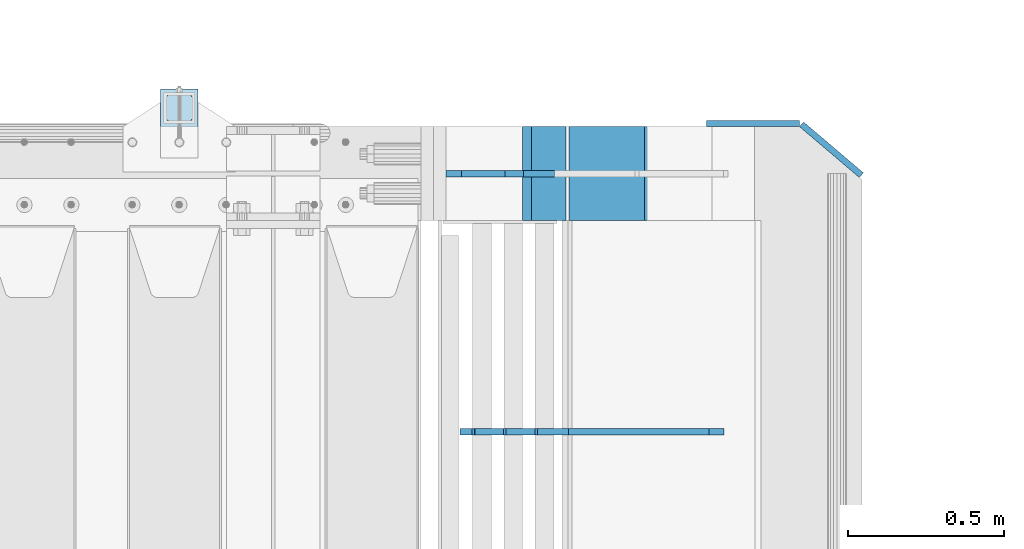
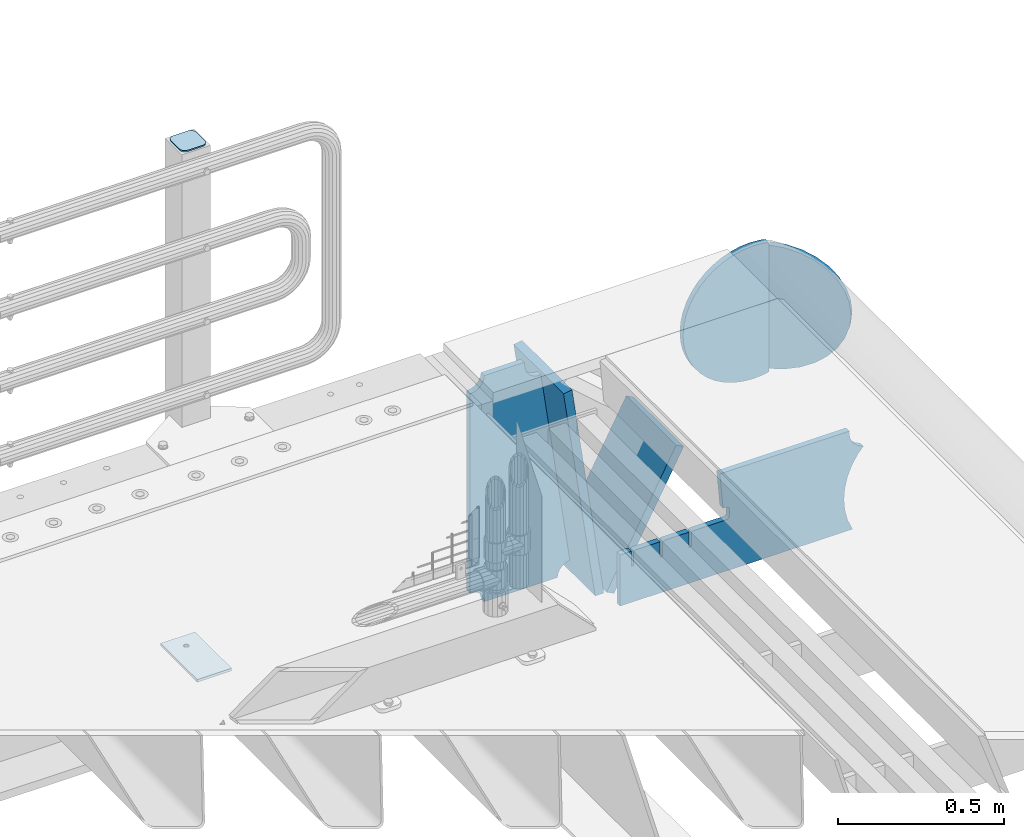
# One storey, part 232 of 247: 8 plates.
"""IFC2X3 building model written with IfcOpenShell, lengths in millimetres."""

from ifc_helpers import new_model, si_unit, frame, origin_with_axes, place, context, subcontext, project, spatial, faceted_brep, material, type_object, element, save


model = new_model("IFC2X3")

# Units and contexts
model_context = context("Model", 3, precision=1e-05, world=origin_with_axes())
body_context = subcontext(model_context, "Body", "Model", "MODEL_VIEW")
ifc_project = project(units=[si_unit("LENGTHUNIT", "METRE", prefix="MILLI"), si_unit("AREAUNIT", "SQUARE_METRE"), si_unit("VOLUMEUNIT", "CUBIC_METRE"), si_unit("MASSUNIT", "GRAM", prefix="KILO"), si_unit("TIMEUNIT", "SECOND"), si_unit("PLANEANGLEUNIT", "RADIAN"), si_unit("SOLIDANGLEUNIT", "STERADIAN"), si_unit("THERMODYNAMICTEMPERATUREUNIT", "DEGREE_CELSIUS"), si_unit("LUMINOUSINTENSITYUNIT", "LUMEN")], contexts=[model_context])

# Site, building, storey
site_placement = place(None, origin_with_axes())
site = spatial("IfcSite", under=ifc_project, at=site_placement, CompositionType="ELEMENT")
building_placement = place(site_placement, origin_with_axes())
building = spatial("IfcBuilding", under=site, at=building_placement, Name="Standard", CompositionType="ELEMENT")
storey_placement = place(building_placement, origin_with_axes())
storey = spatial("IfcBuildingStorey", under=building, at=storey_placement, Name="Undefined", CompositionType="ELEMENT", Elevation=0.0)

# Plates
ifc_material_1 = material(Name="STEEL/S355J2")
plate_type_1 = type_object("IfcPlateType", PredefinedType="NOTDEFINED")
plate_1_placement = place(storey_placement, frame((15985.0000000001, 9050.00000000021, -850.000000000002), z_axis=(0.0, 1.0, 0.0), x_axis=(1.0, 0.0, 0.0)))
element("IfcPlate", 1, at=plate_1_placement, inside=storey, type_object=plate_type_1, material=ifc_material_1, context=body_context, shape_type="Brep", body=[
    faceted_brep([(66.3639610305399, -5.0, 163.636038969113), (66.3639610305399, 5.0, 163.636038969113), (59.9999999998618, 5.0, 160.999999999791), (59.9999999998618, -5.0, 160.999999999791), (53.6360389691836, 5.0, 163.636038969113), (53.6360389691836, -5.0, 163.636038969113), (50.9999999998618, 5.0, 169.999999999791), (50.9999999998618, -5.0, 169.999999999791), (53.6360389691836, 5.0, 176.363961030469), (53.6360389691836, -5.0, 176.363961030469), (59.9999999998618, 5.0, 178.999999999791), (59.9999999998618, -5.0, 178.999999999791), (66.3639610305399, 5.0, 176.363961030469), (66.3639610305399, -5.0, 176.363961030469), (68.9999999998618, 5.0, 169.999999999791), (68.9999999998618, -5.0, 169.999999999791), (120.0, -5.0, 0.0), (120.0, -5.0, 220.0), (0.0, -5.0, 220.0), (9.04219632502645e-09, -5.00000000143385, -2.89173840428703e-09), (7.66340235713869e-09, 4.99999999856618, -2.89173840428703e-09), (120.0, 5.0, 0.0), (120.0, 5.0, 220.0), (0.0, 5.0, 220.0)], [[[0, 1, 2, 3]], [[3, 2, 4, 5]], [[5, 4, 6, 7]], [[7, 6, 8, 9]], [[9, 8, 10, 11]], [[11, 10, 12, 13]], [[13, 12, 14, 15]], [[15, 14, 1, 0]], [[16, 17, 18, 19], [3, 5, 7, 9, 11, 13, 15, 0]], [[16, 19, 20, 21]], [[17, 16, 21, 22]], [[18, 17, 22, 23]], [[19, 18, 23, 20]], [[22, 21, 20, 23], [10, 8, 6, 4, 2, 1, 14, 12]]]),
])
plate_type_2 = type_object("IfcPlateType", PredefinedType="NOTDEFINED")
plate_2_placement = place(storey_placement, frame((16089.0000000001, 9166.00000000021, 1012.50000000001), z_axis=(0.0, 1.0, 0.0), x_axis=(-1.0, 0.0, 0.0)))
element("IfcPlate", 2, at=plate_2_placement, inside=storey, type_object=plate_type_2, material=ifc_material_1, context=body_context, shape_type="Brep", body=[
    faceted_brep([(0.0, -2.5, 19.0), (0.0, -2.5, 69.0), (0.0, 2.5, 69.0), (0.0, 2.5, 19.0), (0.476369668545885, -2.5, 73.2278977451697), (0.476369668545885, 2.5, 73.2278977451697), (1.88159150985484, -2.5, 77.2437910432327), (1.88159150985484, 2.5, 77.2437910432327), (4.14520183310742, -2.5, 80.8463062353167), (4.14520183310742, 2.5, 80.8463062353167), (7.15369376468334, -2.5, 83.8547981668926), (7.15369376468334, 2.5, 83.8547981668926), (10.7562089567673, -2.5, 86.1184084901452), (10.7562089567673, 2.5, 86.1184084901452), (14.7721022548303, -2.5, 87.5236303314541), (14.7721022548303, 2.5, 87.5236303314541), (19.0, -2.5, 88.0), (19.0, 2.5, 88.0), (69.0, -2.5, 88.0), (69.0, 2.5, 88.0), (73.2278977451697, -2.5, 87.5236303314541), (73.2278977451697, 2.5, 87.5236303314541), (77.2437910432327, -2.5, 86.1184084901452), (77.2437910432327, 2.5, 86.1184084901452), (80.8463062353167, -2.5, 83.8547981668926), (80.8463062353167, 2.5, 83.8547981668926), (83.8547981668926, -2.5, 80.8463062353167), (83.8547981668926, 2.5, 80.8463062353167), (86.1184084901452, -2.5, 77.2437910432327), (86.1184084901452, 2.5, 77.2437910432327), (87.5236303314541, -2.5, 73.2278977451697), (87.5236303314541, 2.5, 73.2278977451697), (88.0, -2.5, 69.0), (88.0, 2.5, 69.0), (88.0, -2.5, 19.0), (88.0, 2.5, 19.0), (87.5236303314541, -2.5, 14.7721022548303), (87.5236303314541, 2.5, 14.7721022548303), (86.1184084901452, -2.5, 10.7562089567673), (86.1184084901452, 2.5, 10.7562089567673), (83.8547981668926, -2.5, 7.15369376468334), (83.8547981668926, 2.5, 7.15369376468334), (80.8463062353167, -2.5, 4.14520183310742), (80.8463062353167, 2.5, 4.14520183310742), (77.2437910432345, -2.5, 1.88159150985484), (77.2437910432345, 2.5, 1.88159150985484), (73.2278977451697, -2.5, 0.476369668545885), (73.2278977451697, 2.5, 0.476369668545885), (69.0, -2.5, 0.0), (69.0, 2.5, 0.0), (19.0, -2.5, 0.0), (19.0, 2.5, 0.0), (14.7721022548303, -2.5, 0.476369668545885), (14.7721022548303, 2.5, 0.476369668545885), (10.7562089567673, -2.5, 1.88159150985484), (10.7562089567673, 2.5, 1.88159150985484), (7.15369376468334, -2.5, 4.14520183310742), (7.15369376468334, 2.5, 4.14520183310742), (4.14520183310742, -2.5, 7.15369376468334), (4.14520183310742, 2.5, 7.15369376468334), (1.88159150985484, -2.5, 10.7562089567673), (1.88159150985484, 2.5, 10.7562089567673), (0.476369668545885, -2.5, 14.7721022548303), (0.476369668545885, 2.5, 14.7721022548303)], [[[0, 1, 2, 3]], [[1, 4, 5, 2]], [[4, 6, 7, 5]], [[6, 8, 9, 7]], [[8, 10, 11, 9]], [[10, 12, 13, 11]], [[12, 14, 15, 13]], [[14, 16, 17, 15]], [[16, 18, 19, 17]], [[18, 20, 21, 19]], [[20, 22, 23, 21]], [[22, 24, 25, 23]], [[24, 26, 27, 25]], [[26, 28, 29, 27]], [[28, 30, 31, 29]], [[30, 32, 33, 31]], [[32, 34, 35, 33]], [[34, 36, 37, 35]], [[36, 38, 39, 37]], [[38, 40, 41, 39]], [[40, 42, 43, 41]], [[42, 44, 45, 43]], [[44, 46, 47, 45]], [[46, 48, 49, 47]], [[48, 50, 51, 49]], [[50, 52, 53, 51]], [[52, 54, 55, 53]], [[54, 56, 57, 55]], [[56, 58, 59, 57]], [[58, 60, 61, 59]], [[60, 62, 63, 61]], [[62, 0, 3, 63]], [[5, 7, 9, 11, 13, 15, 17, 19, 21, 23, 25, 27, 29, 31, 33, 35, 37, 39, 41, 43, 45, 47, 49, 51, 53, 55, 57, 59, 61, 63, 3, 2]], [[62, 60, 58, 56, 54, 52, 50, 48, 46, 44, 42, 40, 38, 36, 34, 32, 30, 28, 26, 24, 22, 20, 18, 16, 14, 12, 10, 8, 6, 4, 1, 0]]]),
])
ifc_material_2 = material(Name="STEEL/S355N")
plate_type_3 = type_object("IfcPlateType", PredefinedType="NOTDEFINED")
plate_3_placement = place(storey_placement, frame((17782.9182339676, 8174.99928283691, -374.002067436516), z_axis=(0.0, 0.0, 1.0), x_axis=(-1.0, 0.0, 0.0)))
element("IfcPlate", 3, at=plate_3_placement, inside=storey, type_object=plate_type_3, material=ifc_material_2, context=body_context, shape_type="Brep", body=[
    faceted_brep([(801.919404066546, -10.0, 188.0), (801.919404066546, 10.0, 188.0), (801.919404066546, 10.0, 132.002067436952), (801.919404066546, -10.0, 132.002067436952), (793.919404066546, 10.0, 132.002067436952), (793.919404066546, -10.0, 132.002067436952), (793.919404066546, 10.0, 180.002067436952), (793.919404066546, -10.0, 180.002067436952), (793.527856196906, 10.0, 182.474203391951), (793.527856196906, -10.0, 182.474203391951), (792.391540021545, 10.0, 184.704349455291), (792.391540021545, -10.0, 184.704349455291), (790.621686084887, 10.0, 186.474203391951), (790.621686084887, -10.0, 186.474203391951), (788.391540021545, 10.0, 187.610519567313), (788.391540021545, -10.0, 187.610519567313), (785.919404066546, -10.0, 188.002067436952), (785.919404066546, 10.0, 188.0), (841.0, -10.0, 188.0), (841.0, -10.0, 0.0), (841.0, 10.0, 0.0), (841.0, 10.0, 188.0), (33.3619566736015, -10.0, 0.0), (33.3619566736015, 10.0, 0.0), (36.2350612208174, -10.0, 4.68848050267013), (36.2350612208174, 10.0, 4.68848050267013), (51.4877592159428, -10.0, 41.5117508652784), (51.4877592159428, 10.0, 41.5117508652784), (60.792242588137, -10.0, 80.2677133162964), (60.792242588137, 10.0, 80.2677133162964), (63.9194040769726, -10.0, 120.002067436515), (63.9194040769726, 10.0, 120.002067436515), (60.792242588137, -10.0, 159.736421556734), (60.792242588137, 10.0, 159.736421556734), (51.4877592159428, -10.0, 198.492384007752), (51.4877592159428, 10.0, 198.492384007752), (36.2350612208174, -10.0, 235.31565437036), (36.2350612208174, 10.0, 235.31565437036), (15.4097206482074, -10.0, 269.299521518803), (15.4097206482074, 10.0, 269.299521518803), (-3.35474438098754, -10.0, 291.269887256574), (-3.35474438098754, 10.0, 291.269887256574), (-2.36881039375294, -10.0, 291.426043859339), (-2.36881039375294, 10.0, 291.426043859339), (17.1449676604716, -10.0, 301.368810393754), (17.1449676604716, 10.0, 301.368810393754), (32.6311896062471, -10.0, 316.855032339527), (32.6311896062471, 10.0, 316.855032339527), (42.573956140659, -10.0, 336.368810393754), (42.573956140659, 10.0, 336.368810393754), (46.0, -10.0, 358.0), (46.0, 10.0, 358.0), (45.0495205499137, -10.0, 364.001091067617), (45.0495205499137, 10.0, 364.001091067617), (495.040008544922, -10.0, 364.010009765625), (495.040008544922, 10.0, 364.010009765625), (483.600036621094, -10.0, 233.759994506836), (483.600036621094, 10.0, 233.759994506836), (472.0, -10.0, 233.759994506836), (472.0, 10.0, 233.759994506836), (468.909830056251, -10.0, 233.270559669787), (468.909830056251, 10.0, 233.270559669787), (466.122147477075, -10.0, 231.850164450585), (466.122147477075, 10.0, 231.850164450585), (463.909830056251, -10.0, 229.637847029761), (463.909830056251, 10.0, 229.637847029761), (462.489434837047, -10.0, 226.850164450585), (462.489434837047, 10.0, 226.850164450585), (462.0, -10.0, 223.759994506836), (462.0, 10.0, 223.759994506836), (462.0, -10.0, 198.0), (462.0, 10.0, 198.0), (462.489434837047, -10.0, 194.909830056251), (462.489434837047, 10.0, 194.909830056251), (463.909830056251, -10.0, 192.122147477075), (463.909830056251, 10.0, 192.122147477075), (466.122147477075, -10.0, 189.909830056251), (466.122147477075, 10.0, 189.909830056251), (468.909830056251, -10.0, 188.489434837048), (468.909830056251, 10.0, 188.489434837048), (472.0, -10.0, 188.0), (472.0, 10.0, 188.0), (585.919404066546, -10.0, 188.002067436952), (585.919404066546, 10.0, 188.0), (588.391540021545, -10.0, 187.610519567313), (588.391540021545, 10.0, 187.610519567313), (590.621686084887, -10.0, 186.474203391951), (590.621686084887, 10.0, 186.474203391951), (592.391540021545, -10.0, 184.704349455291), (592.391540021545, 10.0, 184.704349455291), (593.527856196906, -10.0, 182.474203391951), (593.527856196906, 10.0, 182.474203391951), (593.919404066546, -10.0, 180.002067436952), (593.919404066546, 10.0, 180.002067436952), (593.919404066546, -10.0, 132.002067436952), (593.919404066546, 10.0, 132.002067436952), (601.919404066546, -10.0, 132.002067436952), (601.919404066546, 10.0, 132.002067436952), (601.919404066546, -10.0, 188.0), (601.919404066546, 10.0, 188.0), (685.919404066546, -10.0, 188.002067436952), (685.919404066546, 10.0, 188.0), (688.391540021545, -10.0, 187.610519567313), (688.391540021545, 10.0, 187.610519567313), (690.621686084887, -10.0, 186.474203391951), (690.621686084887, 10.0, 186.474203391951), (692.391540021545, -10.0, 184.704349455291), (692.391540021545, 10.0, 184.704349455291), (693.527856196906, -10.0, 182.474203391951), (693.527856196906, 10.0, 182.474203391951), (693.919404066546, -10.0, 180.002067436952), (693.919404066546, 10.0, 180.002067436952), (693.919404066546, -10.0, 132.002067436952), (693.919404066546, 10.0, 132.002067436952), (701.919404066546, -10.0, 132.002067436952), (701.919404066546, 10.0, 132.002067436952), (701.919404066546, -10.0, 188.0), (701.919404066546, 10.0, 188.0)], [[[0, 1, 2, 3]], [[3, 2, 4, 5]], [[5, 4, 6, 7]], [[7, 6, 8, 9]], [[9, 8, 10, 11]], [[11, 10, 12, 13]], [[13, 12, 14, 15]], [[16, 15, 14, 17]], [[18, 19, 20, 21]], [[20, 19, 22, 23]], [[22, 24, 25, 23]], [[26, 27, 25, 24]], [[28, 29, 27, 26]], [[30, 31, 29, 28]], [[32, 33, 31, 30]], [[34, 35, 33, 32]], [[36, 37, 35, 34]], [[38, 39, 37, 36]], [[39, 38, 40, 41]], [[40, 42, 43, 41]], [[44, 45, 43, 42]], [[46, 47, 45, 44]], [[48, 49, 47, 46]], [[50, 51, 49, 48]], [[52, 53, 51, 50]], [[54, 55, 53, 52]], [[54, 56, 57, 55]], [[56, 58, 59, 57]], [[58, 60, 61, 59]], [[60, 62, 63, 61]], [[62, 64, 65, 63]], [[64, 66, 67, 65]], [[66, 68, 69, 67]], [[68, 70, 71, 69]], [[70, 72, 73, 71]], [[72, 74, 75, 73]], [[74, 76, 77, 75]], [[76, 78, 79, 77]], [[78, 80, 81, 79]], [[81, 80, 82, 83]], [[82, 84, 85, 83]], [[86, 87, 85, 84]], [[88, 89, 87, 86]], [[90, 91, 89, 88]], [[92, 93, 91, 90]], [[94, 95, 93, 92]], [[96, 97, 95, 94]], [[98, 99, 97, 96]], [[99, 98, 100, 101]], [[100, 102, 103, 101]], [[104, 105, 103, 102]], [[106, 107, 105, 104]], [[108, 109, 107, 106]], [[110, 111, 109, 108]], [[112, 113, 111, 110]], [[114, 115, 113, 112]], [[116, 117, 115, 114]], [[117, 116, 16, 17]], [[12, 10, 8, 6, 4, 2, 1, 21, 20, 23, 25, 27, 29, 31, 33, 35, 37, 39, 41, 43, 45, 47, 49, 51, 53, 55, 57, 59, 61, 63, 65, 67, 69, 71, 73, 75, 77, 79, 81, 83, 85, 87, 89, 91, 93, 95, 97, 99, 101, 103, 105, 107, 109, 111, 113, 115, 117, 17, 14]], [[18, 21, 1, 0]], [[116, 114, 112, 110, 108, 106, 104, 102, 100, 98, 96, 94, 92, 90, 88, 86, 84, 82, 80, 78, 76, 74, 72, 70, 68, 66, 64, 62, 60, 58, 56, 54, 52, 50, 48, 46, 44, 42, 40, 38, 36, 34, 32, 30, 28, 26, 24, 22, 19, 18, 0, 3, 5, 7, 9, 11, 13, 15, 16]]]),
])
plate_type_4 = type_object("IfcPlateType", PredefinedType="NOTDEFINED")
plate_4_placement = place(storey_placement, frame((17135.998829889, 9000.0, -30.0000000032531), z_axis=(0.0, 0.0, -1.0), x_axis=(-1.0, 0.0, 0.0)))
element("IfcPlate", 4, at=plate_4_placement, inside=storey, type_object=plate_type_4, material=ifc_material_2, context=body_context, shape_type="Brep", body=[
    faceted_brep([(-9.00602409638668, -10.0, 65.0), (-108.137843376921, -10.0, 780.473130459514), (-108.137843376921, 10.0, 780.473130459514), (-9.00602409638668, 10.0, 65.0), (-94.4157884488377, -10.0, 784.433672138112), (-94.4157884488377, 10.0, 784.433672138112), (-82.3732461236723, -10.0, 792.112074067144), (-82.3732461236723, 10.0, 792.112074067144), (-72.9927947992364, -10.0, 802.881837982249), (-72.9927947992364, 10.0, 802.881837982249), (-67.0398068183713, -10.0, 815.864234368775), (-67.0398068183713, 10.0, 815.864234368775), (-65.0, -10.0, 830.0), (-65.0, 10.0, 830.0), (189.0, -10.0, 830.0), (189.0, 10.0, 830.0), (191.447174185243, -10.0, 814.549150281253), (191.447174185243, 10.0, 814.549150281253), (198.549150281251, -10.0, 800.610737385376), (198.549150281251, 10.0, 800.610737385376), (209.610737385377, -10.0, 789.549150281253), (209.610737385377, 10.0, 789.549150281253), (223.549150281251, -10.0, 782.447174185242), (223.549150281251, 10.0, 782.447174185242), (239.0, -10.0, 780.0), (239.0, 10.0, 780.0), (239.0, -10.0, 50.0), (239.0, 10.0, 50.0), (223.549150281251, -10.0, 47.5528258147577), (223.549150281251, 10.0, 47.5528258147577), (209.610737385377, -10.0, 40.4508497187474), (209.610737385377, 10.0, 40.4508497187474), (198.549150281251, -10.0, 29.3892626146237), (198.549150281251, 10.0, 29.3892626146237), (191.447174185243, -10.0, 15.4508497187474), (191.447174185243, 10.0, 15.4508497187474), (189.0, -10.0, 0.0), (189.0, 10.0, 0.0), (50.4776502774184, -10.0, 0.0), (50.4776502774184, 10.0, 0.0), (47.3830020671812, -10.0, 22.3352870825933), (47.3830020671812, 10.0, 22.3352870825933), (42.8384615202776, -10.0, 37.3040735979326), (42.8384615202776, 10.0, 37.3040735979326), (33.8907372011709, -10.0, 50.1358952937587), (33.8907372011709, 10.0, 50.1358952937587), (21.4156947086703, -10.0, 59.5746840579253), (21.4156947086703, 10.0, 59.5746840579253), (6.63447812067898, -10.0, 64.6965054822873), (6.63447812067898, 10.0, 64.6965054822873)], [[[0, 1, 2, 3]], [[1, 4, 5, 2]], [[4, 6, 7, 5]], [[6, 8, 9, 7]], [[8, 10, 11, 9]], [[10, 12, 13, 11]], [[12, 14, 15, 13]], [[14, 16, 17, 15]], [[16, 18, 19, 17]], [[18, 20, 21, 19]], [[20, 22, 23, 21]], [[22, 24, 25, 23]], [[24, 26, 27, 25]], [[26, 28, 29, 27]], [[28, 30, 31, 29]], [[30, 32, 33, 31]], [[32, 34, 35, 33]], [[34, 36, 37, 35]], [[36, 38, 39, 37]], [[38, 40, 41, 39]], [[40, 42, 43, 41]], [[42, 44, 45, 43]], [[44, 46, 47, 45]], [[46, 48, 49, 47]], [[48, 0, 3, 49]], [[5, 7, 9, 11, 13, 15, 17, 19, 21, 23, 25, 27, 29, 31, 33, 35, 37, 39, 41, 43, 45, 47, 49, 3, 2]], [[48, 46, 44, 42, 40, 38, 36, 34, 32, 30, 28, 26, 24, 22, 20, 18, 16, 14, 12, 10, 8, 6, 4, 1, 0]]]),
])
plate_type_5 = type_object("IfcPlateType", PredefinedType="NOTDEFINED")
plate_5_placement = place(storey_placement, frame((17266.1480677219, 9150.000000001, -862.083788721732), z_axis=(-0.139173011053008, 0.0, 0.990268081377179), x_axis=(0.0, -0.999999999999548, -9.5100000000016e-07)))
element("IfcPlate", 5, at=plate_5_placement, inside=storey, type_object=plate_type_5, material=ifc_material_2, context=body_context, shape_type="Brep", body=[
    faceted_brep([(1.00411057246674e-09, 14.9994702460535, -0.00376939767329532), (300.0, 15.0, 0.0), (300.0, -15.0, 4.21237841386937), (0.0, -15.0, 4.21237841386937), (0.0, -14.9999999999964, 792.0), (300.0, -14.9999999999964, 792.0), (300.0, 15.0, 792.0), (0.0, 15.0, 792.0)], [[[0, 1, 2, 3]], [[4, 5, 6, 7]], [[4, 7, 0, 3]], [[5, 4, 3, 2]], [[6, 5, 2, 1]], [[7, 6, 1, 0]]]),
])
plate_6_placement = place(storey_placement, frame((17303.2468009566, 9150.000000001, -867.038754739308), z_axis=(0.469471552246176, 0.0, 0.882947598462992), x_axis=(0.0, -0.999999999999548, -9.5100000000016e-07)))
element("IfcPlate", 6, at=plate_6_placement, inside=storey, type_object=plate_type_5, material=ifc_material_2, context=body_context, shape_type="Brep", body=[
    faceted_brep([(0.0, -15.0, 0.0), (0.0, -15.0, 514.999999999999), (0.0, 15.0000000000018, 515.000000000001), (0.0, 15.0, 0.0), (300.0, -15.0, 514.999999999999), (300.0, 15.0000000000018, 515.000000000001), (300.0, -15.0, 0.0), (300.0, 15.0, 0.0)], [[[0, 1, 2, 3]], [[1, 4, 5, 2]], [[4, 6, 7, 5]], [[6, 0, 3, 7]], [[5, 7, 3, 2]], [[6, 4, 1, 0]]]),
])
plate_type_6 = type_object("IfcPlateType", PredefinedType="NOTDEFINED")
plate_7_placement = place(storey_placement, frame((18216.9988298906, 9160.0, -498.000000000001), z_axis=(0.0, 0.0, 1.0), x_axis=(-1.0, 0.0, 0.0)))
element("IfcPlate", 7, at=plate_7_placement, inside=storey, type_object=plate_type_6, material=ifc_material_2, context=body_context, shape_type="Brep", body=[
    faceted_brep([(244.0, -10.0, 0.0), (209.275179461318, -10.0, 2.48356818105242), (209.275179461318, 10.0, 2.48356818105242), (244.0, 10.0, 0.0), (278.724820538682, -10.0, 2.48356818105236), (278.724820538682, 10.0, 2.48356818105236), (312.742743869308, -10.0, 9.88371443806261), (312.742743869308, 10.0, 9.88371443806261), (345.361263172461, -10.0, 22.0497931334975), (345.361263172461, 10.0, 22.0497931334975), (375.916359459166, -10.0, 38.7341379891918), (375.916359459166, 10.0, 38.7341379891918), (403.78601908265, -10.0, 59.597103857561), (403.78601908265, 10.0, 59.597103857561), (428.402896142437, -10.0, 84.2139809173505), (428.402896142437, 10.0, 84.2139809173505), (449.265862010809, -10.0, 112.083640540834), (449.265862010809, 10.0, 112.083640540834), (465.950206866502, -10.0, 142.63873682754), (465.950206866502, 10.0, 142.63873682754), (478.116285561937, -10.0, 175.257256130691), (478.116285561937, 10.0, 175.257256130691), (485.516431818949, -10.0, 209.275179461318), (485.516431818949, 10.0, 209.275179461318), (488.0, -10.0, 244.0), (488.0, 10.0, 244.0), (485.516431818949, -10.0, 278.724820538682), (485.516431818949, 10.0, 278.724820538682), (478.116285561937, -10.0, 312.742743869309), (478.116285561937, 10.0, 312.742743869309), (465.950206866502, -10.0, 345.36126317246), (465.950206866502, 10.0, 345.36126317246), (449.265862010809, -10.0, 375.916359459166), (449.265862010809, 10.0, 375.916359459166), (428.402896142437, -10.0, 403.78601908265), (428.402896142437, 10.0, 403.78601908265), (403.78601908265, -10.0, 428.402896142439), (403.78601908265, 10.0, 428.402896142439), (375.916359459166, -10.0, 449.265862010808), (375.916359459166, 10.0, 449.265862010808), (345.361263172461, -10.0, 465.950206866503), (345.361263172461, 10.0, 465.950206866503), (312.742743869308, -10.0, 478.116285561937), (312.742743869308, 10.0, 478.116285561937), (278.724820538682, -10.0, 485.516431818948), (278.724820538682, 10.0, 485.516431818948), (244.0, -10.0, 488.0), (244.0, 10.0, 488.0), (209.275179461318, -10.0, 485.516431818948), (209.275179461318, 10.0, 485.516431818948), (190.05541508122, -10.0, 481.335427997649), (190.058547913373, -10.0, 6.66389049643158), (190.053997906722, 10.0, 6.66488028979336), (190.050865087636, 10.0, 481.334438207129)], [[[0, 1, 2, 3]], [[4, 0, 3, 5]], [[6, 4, 5, 7]], [[8, 6, 7, 9]], [[10, 8, 9, 11]], [[12, 10, 11, 13]], [[14, 12, 13, 15]], [[16, 14, 15, 17]], [[18, 16, 17, 19]], [[20, 18, 19, 21]], [[22, 20, 21, 23]], [[24, 22, 23, 25]], [[26, 24, 25, 27]], [[28, 26, 27, 29]], [[30, 28, 29, 31]], [[32, 30, 31, 33]], [[34, 32, 33, 35]], [[36, 34, 35, 37]], [[38, 36, 37, 39]], [[40, 38, 39, 41]], [[42, 40, 41, 43]], [[44, 42, 43, 45]], [[46, 44, 45, 47]], [[48, 46, 47, 49]], [[1, 0, 4, 6, 8, 10, 12, 14, 16, 18, 20, 22, 24, 26, 28, 30, 32, 34, 36, 38, 40, 42, 44, 46, 48, 50, 51]], [[2, 1, 51, 52]], [[49, 47, 45, 43, 41, 39, 37, 35, 33, 31, 29, 27, 25, 23, 21, 19, 17, 15, 13, 11, 9, 7, 5, 3, 2, 52, 53]], [[48, 49, 53, 50]], [[52, 51, 50, 53]]]),
])
plate_type_7 = type_object("IfcPlateType", PredefinedType="NOTDEFINED")
plate_8_placement = place(storey_placement, frame((18070.6680552572, 9125.95314920567, -30.6119535183306), z_axis=(-0.0673151699806107, 0.0572188599835183, -0.996089689713064), x_axis=(-0.758954680570074, 0.645122052634529, 0.0883477789499519)))
element("IfcPlate", 8, at=plate_8_placement, inside=storey, type_object=plate_type_7, material=ifc_material_2, context=body_context, shape_type="Brep", body=[
    faceted_brep([(-5.6843418860808e-14, -9.99999999999989, 3.5527136788005e-15), (-48.0501251221722, -9.99999999999636, 8.67006015777542), (-48.0501251221704, 10.0, 8.67006015777554), (-5.6843418860808e-14, 10.0000000000001, 3.5527136788005e-15), (-93.1325836184515, -10.0, 25.6772422790525), (-93.1325836184524, 10.0, 25.6772422790525), (-133.519607544506, -9.99999999999636, 50.3672103881835), (-133.519607544506, 10.0000000000036, 50.3672103881835), (-167.654617310479, -9.99999999999636, 81.79231262207), (-167.654617310478, 10.0000000000036, 81.79231262207), (-194.116653443697, -9.99999999999636, 118.75399017334), (-194.116653443699, 10.0000000000036, 118.75399017334), (-212.219375612121, -9.99999999999636, 159.802307128906), (-212.219375612121, 10.0000000000036, 159.802307128906), (-220.935668947562, -10.0, 203.390228271484), (-220.935668947563, 10.0, 203.390228271484), (-220.042388918758, -9.99999999999636, 247.831420898437), (-220.042388918756, 10.0, 247.831420898437), (-209.44876098955, -9.99999999999636, 291.430206298828), (-209.448760989547, 10.0, 291.430206298828), (-189.93119812379, -10.0, 332.47769165039), (-189.931198123792, 10.0000000000036, 332.47769165039), (-161.872329715996, -10.0, 369.429595947265), (-161.872329715995, 10.0000000000036, 369.429595947265), (-126.473861698763, -9.99999999999636, 400.854248046875), (-126.473861698765, 10.0000000000036, 400.854248046875), (-85.0954742478634, -9.99999999999636, 425.544403076172), (-85.0954742478643, 10.0000000000036, 425.544403076172), (-39.3266487170467, -10.0, 442.551971435547), (-39.3266487170467, 10.0000000000036, 442.551971435547), (9.07161902882854, -10.0, 451.221954345703), (9.07161902882854, 10.0000000000036, 451.221954345703), (49.1691665649378, -10.0, 5.10453901370056e-11), (49.1691665649359, 10.0000000000036, 5.10453901370056e-11)], [[[0, 1, 2, 3]], [[1, 4, 5, 2]], [[4, 6, 7, 5]], [[6, 8, 9, 7]], [[8, 10, 11, 9]], [[10, 12, 13, 11]], [[12, 14, 15, 13]], [[14, 16, 17, 15]], [[16, 18, 19, 17]], [[18, 20, 21, 19]], [[20, 22, 23, 21]], [[22, 24, 25, 23]], [[24, 26, 27, 25]], [[26, 28, 29, 27]], [[28, 30, 31, 29]], [[30, 32, 33, 31]], [[32, 0, 3, 33]], [[5, 7, 9, 11, 13, 15, 17, 19, 21, 23, 25, 27, 29, 31, 33, 3, 2]], [[32, 30, 28, 26, 24, 22, 20, 18, 16, 14, 12, 10, 8, 6, 4, 1, 0]]]),
])

save(model, "model.ifc")
